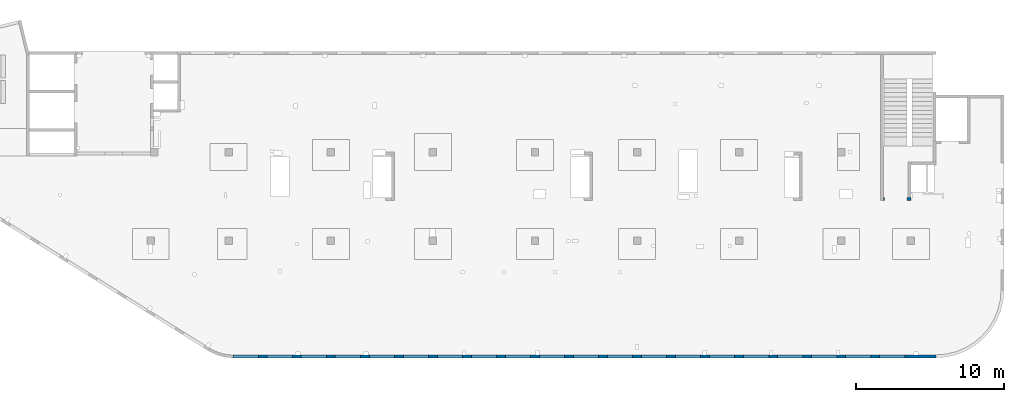
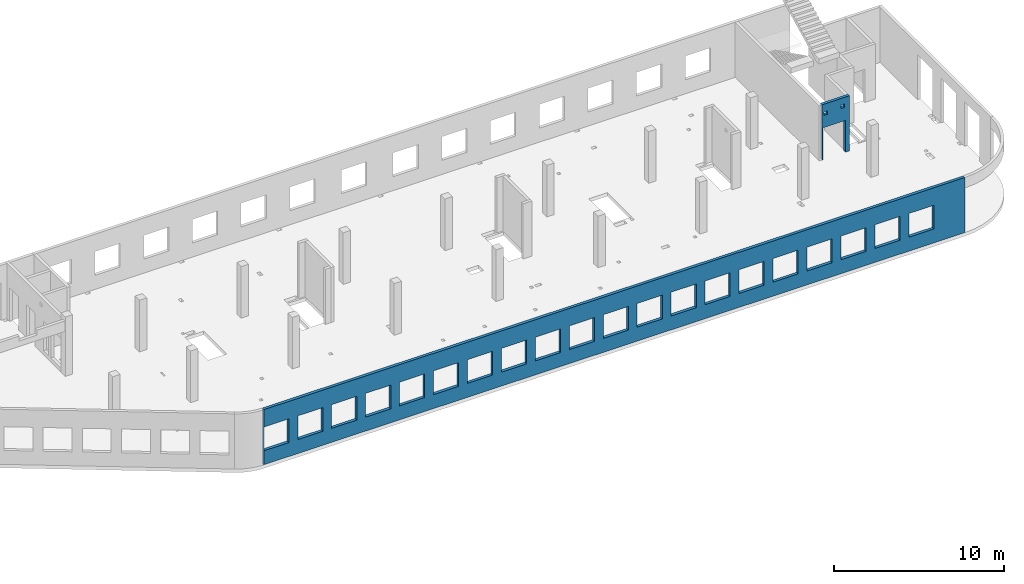
# One storey, part 66 of 67: 2 walls, 23 openings.
"""IFC4 building model written with IfcOpenShell, lengths in millimetres."""

from ifc_helpers import new_model, entity, si_unit, converted_unit, derived_unit, direction, frame, origin, place, context, subcontext, project, spatial, indexed_curve, outline, extrude, polygons, material, type_object, element, save


model = new_model("IFC4")

# Units and contexts
model_context = context("Model", 3, precision=0.01, world=origin(), true_north=direction((6.12303176911189e-17, 1.0)))
plan_context = context("Plan", 3, precision=0.01, world=origin(), true_north=direction((6.12303176911189e-17, 1.0)))
body_context = subcontext(model_context, "Body", "Model", "MODEL_VIEW")
ifc_project = project(units=[si_unit("LENGTHUNIT", "METRE", prefix="MILLI"), si_unit("AREAUNIT", "SQUARE_METRE"), si_unit("VOLUMEUNIT", "CUBIC_METRE"), converted_unit("PLANEANGLEUNIT", "DEGREE", entity("IfcRatioMeasure", 0.0174532925199433), si_unit("PLANEANGLEUNIT", "RADIAN"), dimensions=[0, 0, 0, 0, 0, 0, 0]), si_unit("MASSUNIT", "GRAM", prefix="KILO"), derived_unit("MASSDENSITYUNIT", [(si_unit("MASSUNIT", "GRAM", prefix="KILO"), 1), (si_unit("LENGTHUNIT", "METRE"), -3)]), derived_unit("MOMENTOFINERTIAUNIT", [(si_unit("LENGTHUNIT", "METRE"), 4)]), si_unit("TIMEUNIT", "SECOND"), si_unit("FREQUENCYUNIT", "HERTZ"), si_unit("THERMODYNAMICTEMPERATUREUNIT", "DEGREE_CELSIUS"), derived_unit("THERMALTRANSMITTANCEUNIT", [(si_unit("MASSUNIT", "GRAM", prefix="KILO"), 1), (si_unit("THERMODYNAMICTEMPERATUREUNIT", "KELVIN"), -1), (si_unit("TIMEUNIT", "SECOND"), -3)]), derived_unit("VOLUMETRICFLOWRATEUNIT", [(si_unit("LENGTHUNIT", "METRE"), 3), (si_unit("TIMEUNIT", "SECOND"), -1)]), derived_unit("MASSFLOWRATEUNIT", [(si_unit("MASSUNIT", "GRAM", prefix="KILO"), 1), (si_unit("TIMEUNIT", "SECOND"), -1)]), derived_unit("ROTATIONALFREQUENCYUNIT", [(si_unit("TIMEUNIT", "SECOND"), -1)]), si_unit("ELECTRICCURRENTUNIT", "AMPERE"), si_unit("ELECTRICVOLTAGEUNIT", "VOLT"), si_unit("POWERUNIT", "WATT"), si_unit("FORCEUNIT", "NEWTON", prefix="KILO"), si_unit("ILLUMINANCEUNIT", "LUX"), si_unit("LUMINOUSFLUXUNIT", "LUMEN"), si_unit("LUMINOUSINTENSITYUNIT", "CANDELA"), derived_unit("USERDEFINED", [(si_unit("MASSUNIT", "GRAM", prefix="KILO"), -1), (si_unit("LENGTHUNIT", "METRE"), -2), (si_unit("TIMEUNIT", "SECOND"), 3), (si_unit("LUMINOUSFLUXUNIT", "LUMEN"), 1)]), derived_unit("LINEARVELOCITYUNIT", [(si_unit("LENGTHUNIT", "METRE"), 1), (si_unit("TIMEUNIT", "SECOND"), -1)]), si_unit("PRESSUREUNIT", "PASCAL"), derived_unit("USERDEFINED", [(si_unit("LENGTHUNIT", "METRE"), -2), (si_unit("MASSUNIT", "GRAM", prefix="KILO"), 1), (si_unit("TIMEUNIT", "SECOND"), -2)]), derived_unit("LINEARFORCEUNIT", [(si_unit("MASSUNIT", "GRAM", prefix="KILO"), 1), (si_unit("LENGTHUNIT", "METRE"), 1), (si_unit("TIMEUNIT", "SECOND"), -2), (si_unit("LENGTHUNIT", "METRE"), -1)]), derived_unit("PLANARFORCEUNIT", [(si_unit("MASSUNIT", "GRAM", prefix="KILO"), 1), (si_unit("LENGTHUNIT", "METRE"), 1), (si_unit("TIMEUNIT", "SECOND"), -2), (si_unit("LENGTHUNIT", "METRE"), -2)])], contexts=[model_context, plan_context])

# Site, building, storey
site_placement = place(None, origin())
site = spatial("IfcSite", under=ifc_project, at=site_placement, CompositionType="ELEMENT")
building_placement = place(site_placement, origin())
building = spatial("IfcBuilding", under=site, at=building_placement, CompositionType="ELEMENT")
storey_placement = place(building_placement, frame((0.0, 0.0, 19800.0)))
storey = spatial("IfcBuildingStorey", under=building, at=storey_placement, CompositionType="ELEMENT", Elevation=19800.0)

# Wall, openings
ifc_material = material()
wall_type = type_object("IfcWallType", PredefinedType="STANDARD")
wall_1_placement = place(storey_placement, frame((21465.0002685547, -100.000773644443, -150.0)))
wall_1 = element("IfcWall", 1, at=wall_1_placement, inside=storey, type_object=wall_type, material=ifc_material, PredefinedType="NOTDEFINED", context=body_context, shape_type="Tessellation", body=[
    polygons([(43705.0, -100.0, 2700.0), (45405.0, -100.0, 2700.0), (45405.0, -100.0, 1000.00000000001), (43705.0, -100.0, 1000.00000000001), (41405.0, -100.0, 2700.0), (43105.0, -100.0, 2700.0), (43105.0, -100.0, 1000.00000000001), (41405.0, -100.0, 1000.00000000001), (39105.0, -100.0, 2700.0), (40805.0, -100.0, 2700.0), (40805.0, -100.0, 1000.00000000001), (39105.0, -100.0, 1000.00000000001), (36805.0, -100.0, 2700.0), (38505.0, -100.0, 2700.0), (38505.0, -100.0, 1000.00000000001), (36805.0, -100.0, 1000.00000000001), (34505.0, -100.0, 2700.0), (36205.0, -100.0, 2700.0), (36205.0, -100.0, 1000.00000000001), (34505.0, -100.0, 1000.00000000001), (27605.0, -100.0, 2700.0), (29305.0, -100.0, 2700.0), (29305.0, -100.0, 1000.00000000001), (27605.0, -100.0, 1000.00000000001), (29905.0, -100.0, 2700.0), (31605.0, -100.0, 2700.0), (31605.0, -100.0, 1000.00000000001), (29905.0, -100.0, 1000.00000000001), (32205.0, -100.0, 2700.0), (33905.0, -100.0, 2700.0), (33905.0, -100.0, 1000.00000000001), (32205.0, -100.0, 1000.00000000001), (20705.0, -100.0, 2700.0), (22405.0, -100.0, 2700.0), (22405.0, -100.0, 1000.00000000001), (20705.0, -100.0, 1000.00000000001), (23005.0, -100.0, 2700.0), (24705.0, -100.0, 2700.0), (24705.0, -100.0, 1000.00000000001), (23005.0, -100.0, 1000.00000000001), (25305.0, -100.0, 2700.0), (27005.0, -100.0, 2700.0), (27005.0, -100.0, 1000.00000000001), (25305.0, -100.0, 1000.00000000001), (13805.0, -100.0, 2700.0), (15505.0, -100.0, 2700.0), (15505.0, -100.0, 1000.00000000001), (13805.0, -100.0, 1000.00000000001), (16105.0, -100.0, 2700.0), (17805.0, -100.0, 2700.0), (17805.0, -100.0, 1000.00000000001), (16105.0, -100.0, 1000.00000000001), (18405.0, -100.0, 2700.0), (20105.0, -100.0, 2700.0), (20105.0, -100.0, 1000.00000000001), (18405.0, -100.0, 1000.00000000001), (6904.99999999999, -100.0, 2700.0), (8604.99999999999, -100.0, 2700.0), (8604.99999999999, -100.0, 1000.00000000001), (6904.99999999999, -100.0, 1000.00000000001), (9205.0, -100.0, 2700.0), (10905.0, -100.0, 2700.0), (10905.0, -100.0, 1000.00000000001), (9205.0, -100.0, 1000.00000000001), (11505.0, -100.0, 2700.0), (13205.0, -100.0, 2700.0), (13205.0, -100.0, 1000.00000000001), (11505.0, -100.0, 1000.00000000001), (2305.0, -100.0, 2700.0), (4005.0, -100.0, 2700.0), (4005.0, -100.0, 1000.00000000001), (2305.0, -100.0, 1000.00000000001), (4605.0, -100.0, 2700.0), (6305.00000000001, -100.0, 2700.0), (6305.00000000001, -100.0, 1000.00000000001), (4605.0, -100.0, 1000.00000000001), (5.00000000000384, -100.0, 2700.0), (1705.0, -100.0, 2700.0), (1705.0, -100.0, 1000.00000000001), (5.00000000000384, -100.0, 1000.00000000001), (6.46235172450444e-13, -100.0, 0.0), (47505.0, -100.0, 0.0), (47505.0, -100.0, 3950.0), (4.65284088467406, -100.0, 3950.0), (4.97770368964401e-12, -100.0, 3950.0), (45405.0, 100.000000000321, 2700.0), (43705.0, 100.000000000321, 2700.0), (43705.0, 100.000000000321, 1000.00000000001), (45405.0, 100.000000000321, 1000.00000000001), (43105.0, 100.000000000321, 2700.0), (41405.0, 100.000000000321, 2700.0), (41405.0, 100.000000000321, 1000.00000000001), (43105.0, 100.000000000321, 1000.00000000001), (40805.0, 100.000000000321, 2700.0), (39105.0, 100.000000000321, 2700.0), (39105.0, 100.000000000321, 1000.00000000001), (40805.0, 100.000000000321, 1000.00000000001), (38505.0, 100.000000000321, 2700.0), (36805.0, 100.000000000321, 2700.0), (36805.0, 100.000000000321, 1000.00000000001), (38505.0, 100.000000000321, 1000.00000000001), (36205.0, 100.000000000321, 2700.0), (34505.0, 100.000000000321, 2700.0), (34505.0, 100.000000000321, 1000.00000000001), (36205.0, 100.000000000321, 1000.00000000001), (29305.0, 100.000000000321, 2700.0), (27605.0, 100.000000000321, 2700.0), (27605.0, 100.000000000321, 1000.00000000001), (29305.0, 100.000000000321, 1000.00000000001), (31605.0, 100.000000000321, 2700.0), (29905.0, 100.000000000321, 2700.0), (29905.0, 100.000000000321, 1000.00000000001), (31605.0, 100.000000000321, 1000.00000000001), (33905.0, 100.000000000321, 2700.0), (32205.0, 100.000000000321, 2700.0), (32205.0, 100.000000000321, 1000.00000000001), (33905.0, 100.000000000321, 1000.00000000001), (22405.0, 100.000000000321, 2700.0), (20705.0, 100.000000000321, 2700.0), (20705.0, 100.000000000321, 1000.00000000001), (22405.0, 100.000000000321, 1000.00000000001), (24705.0, 100.000000000321, 2700.0), (23005.0, 100.000000000321, 2700.0), (23005.0, 100.000000000321, 1000.00000000001), (24705.0, 100.000000000321, 1000.00000000001), (27005.0, 100.000000000321, 2700.0), (25305.0, 100.000000000321, 2700.0), (25305.0, 100.000000000321, 1000.00000000001), (27005.0, 100.000000000321, 1000.00000000001), (15505.0, 100.000000000321, 2700.0), (13805.0, 100.000000000321, 2700.0), (13805.0, 100.000000000321, 1000.00000000001), (15505.0, 100.000000000321, 1000.00000000001), (17805.0, 100.000000000321, 2700.0), (16105.0, 100.000000000321, 2700.0), (16105.0, 100.000000000321, 1000.00000000001), (17805.0, 100.000000000321, 1000.00000000001), (20105.0, 100.000000000321, 2700.0), (18405.0, 100.000000000321, 2700.0), (18405.0, 100.000000000321, 1000.00000000001), (20105.0, 100.000000000321, 1000.00000000001), (8604.99999999998, 100.000000000321, 2700.0), (6904.99999999999, 100.000000000321, 2700.0), (6904.99999999999, 100.000000000321, 1000.00000000001), (8604.99999999998, 100.000000000321, 1000.00000000001), (10905.0, 100.000000000321, 2700.0), (9204.99999999999, 100.000000000321, 2700.0), (9204.99999999999, 100.000000000321, 1000.00000000001), (10905.0, 100.000000000321, 1000.00000000001), (13205.0, 100.000000000321, 2700.0), (11505.0, 100.000000000321, 2700.0), (11505.0, 100.000000000321, 1000.00000000001), (13205.0, 100.000000000321, 1000.00000000001), (4005.0, 100.000000000321, 2700.0), (2305.0, 100.000000000321, 2700.0), (2305.0, 100.000000000321, 1000.00000000001), (4005.0, 100.000000000321, 1000.00000000001), (6305.0, 100.000000000321, 2700.0), (4605.0, 100.000000000321, 2700.0), (4605.0, 100.000000000321, 1000.00000000001), (6305.0, 100.000000000321, 1000.00000000001), (1705.0, 100.000000000321, 2700.0), (5.00000000000319, 100.000000000321, 2700.0), (5.00000000000319, 100.000000000321, 1000.00000000002), (1705.0, 100.000000000321, 1000.00000000002), (47505.0, 100.0, 0.0), (46305.0, 100.0, 0.0), (46005.0, 100.0, 0.0), (40985.0, 100.0, 0.0), (40785.0, 100.0, 0.0), (36475.0, 100.0, 0.0), (36275.0, 100.0, 0.0), (31965.0, 100.0, 0.0), (31765.0, 100.0, 0.0), (20675.0, 100.0, 0.0), (20475.0, 100.0, 0.0), (15725.0, 100.0, 0.0), (15525.0, 100.0, 0.0), (9114.99999999999, 100.0, 0.0), (8814.99999999999, 100.0, 0.0), (4534.99999999999, 100.0, 0.0), (4234.99999999999, 100.0, 0.0), (2.49977157936766e-18, 100.0, 0.0), (4.33147101696515e-12, 100.0, 3950.0), (4234.99999999999, 100.0, 3950.0), (4535.0, 100.0, 3950.0), (8930.0, 100.0, 3950.0), (9130.0, 100.0, 3950.0), (13355.0, 100.0, 3950.0), (13655.0, 100.0, 3950.0), (18105.0, 100.0, 3950.0), (18405.0, 100.0, 3950.0), (24805.0, 100.0, 3950.0), (25105.0, 100.0, 3950.0), (31805.0, 100.0, 3950.0), (32105.0, 100.0, 3950.0), (36405.0, 100.0, 3950.0), (36705.0, 100.0, 3950.0), (41005.0, 100.0, 3950.0), (41305.0, 100.0, 3950.0), (46005.0, 100.0, 3950.0), (46305.0, 100.0, 3950.0), (47505.0, 100.0, 3950.0)], [[[81, 82, 83, 84, 85], [1, 2, 3, 4], [5, 6, 7, 8], [9, 10, 11, 12], [13, 14, 15, 16], [17, 18, 19, 20], [21, 22, 23, 24], [25, 26, 27, 28], [29, 30, 31, 32], [33, 34, 35, 36], [37, 38, 39, 40], [41, 42, 43, 44], [45, 46, 47, 48], [49, 50, 51, 52], [53, 54, 55, 56], [57, 58, 59, 60], [61, 62, 63, 64], [65, 66, 67, 68], [69, 70, 71, 72], [73, 74, 75, 76], [77, 78, 79, 80]], [[166, 167, 168, 169, 170, 171, 172, 173, 174, 175, 176, 177, 178, 179, 180, 181, 182, 183, 184, 185, 186, 187, 188, 189, 190, 191, 192, 193, 194, 195, 196, 197, 198, 199, 200, 201, 202, 203], [86, 87, 88, 89], [90, 91, 92, 93], [94, 95, 96, 97], [98, 99, 100, 101], [102, 103, 104, 105], [106, 107, 108, 109], [110, 111, 112, 113], [114, 115, 116, 117], [118, 119, 120, 121], [122, 123, 124, 125], [126, 127, 128, 129], [130, 131, 132, 133], [134, 135, 136, 137], [138, 139, 140, 141], [142, 143, 144, 145], [146, 147, 148, 149], [150, 151, 152, 153], [154, 155, 156, 157], [158, 159, 160, 161], [162, 163, 164, 165]], [[82, 81, 183, 182, 181, 180, 179, 178, 177, 176, 175, 174, 173, 172, 171, 170, 169, 168, 167, 166]], [[83, 82, 166, 203]], [[85, 84, 83, 203, 202, 201, 200, 199, 198, 197, 196, 195, 194, 193, 192, 191, 190, 189, 188, 187, 186, 185, 184]], [[81, 85, 184, 183]], [[87, 86, 2, 1]], [[87, 1, 4, 88]], [[88, 4, 3, 89]], [[2, 86, 89, 3]], [[91, 90, 6, 5]], [[91, 5, 8, 92]], [[92, 8, 7, 93]], [[6, 90, 93, 7]], [[95, 94, 10, 9]], [[95, 9, 12, 96]], [[96, 12, 11, 97]], [[10, 94, 97, 11]], [[99, 98, 14, 13]], [[99, 13, 16, 100]], [[100, 16, 15, 101]], [[14, 98, 101, 15]], [[103, 102, 18, 17]], [[103, 17, 20, 104]], [[104, 20, 19, 105]], [[18, 102, 105, 19]], [[107, 106, 22, 21]], [[107, 21, 24, 108]], [[108, 24, 23, 109]], [[22, 106, 109, 23]], [[111, 110, 26, 25]], [[111, 25, 28, 112]], [[112, 28, 27, 113]], [[26, 110, 113, 27]], [[115, 114, 30, 29]], [[115, 29, 32, 116]], [[116, 32, 31, 117]], [[30, 114, 117, 31]], [[119, 118, 34, 33]], [[119, 33, 36, 120]], [[120, 36, 35, 121]], [[34, 118, 121, 35]], [[123, 122, 38, 37]], [[123, 37, 40, 124]], [[124, 40, 39, 125]], [[38, 122, 125, 39]], [[127, 126, 42, 41]], [[127, 41, 44, 128]], [[128, 44, 43, 129]], [[42, 126, 129, 43]], [[131, 130, 46, 45]], [[131, 45, 48, 132]], [[132, 48, 47, 133]], [[46, 130, 133, 47]], [[135, 134, 50, 49]], [[135, 49, 52, 136]], [[136, 52, 51, 137]], [[50, 134, 137, 51]], [[139, 138, 54, 53]], [[139, 53, 56, 140]], [[140, 56, 55, 141]], [[54, 138, 141, 55]], [[143, 142, 58, 57]], [[143, 57, 60, 144]], [[144, 60, 59, 145]], [[58, 142, 145, 59]], [[147, 146, 62, 61]], [[147, 61, 64, 148]], [[148, 64, 63, 149]], [[62, 146, 149, 63]], [[151, 150, 66, 65]], [[151, 65, 68, 152]], [[152, 68, 67, 153]], [[66, 150, 153, 67]], [[155, 154, 70, 69]], [[155, 69, 72, 156]], [[156, 72, 71, 157]], [[70, 154, 157, 71]], [[159, 158, 74, 73]], [[159, 73, 76, 160]], [[160, 76, 75, 161]], [[74, 158, 161, 75]], [[77, 163, 162, 78]], [[163, 77, 80, 164]], [[164, 80, 79, 165]], [[78, 162, 165, 79]]], closed=True),
])
opening_1_placement = place(wall_1_placement, frame((-21465.0002685547, 100.000773644443, 150.0)))
element("IfcOpeningElement", 2, at=opening_1_placement, cuts=wall_1, PredefinedType="OPENING", context=body_context, shape_type="SweptSolid", body=[
    extrude(outline(indexed_curve([(-849.999999999993, -850.000000000002), (849.999999999993, -850.000000000002), (849.999999999993, 849.999999999997), (-849.999999999993, 849.999999999997), (-849.999999999993, -850.000000000002)], self_intersect=False)), frame((22320.0002685547, -200.000773644445, 1700.0), z_axis=(0.0, 1.0, 0.0), x_axis=(0.0, 0.0, -1.0)), (0.0, 0.0, 1.0), 200.000000000962),
])
opening_2_placement = place(wall_1_placement, frame((-21465.0002685547, 100.000773644443, 150.0)))
element("IfcOpeningElement", 3, at=opening_2_placement, cuts=wall_1, PredefinedType="OPENING", context=body_context, shape_type="SweptSolid", body=[
    extrude(outline(indexed_curve([(-849.999999999993, -850.000000000006), (849.999999999993, -850.000000000006), (849.999999999993, 849.999999999997), (-849.999999999993, 849.999999999997), (-849.999999999993, -850.000000000006)], self_intersect=False)), frame((66020.0002685547, -200.000773644587, 1700.0), z_axis=(0.0, 1.0, 0.0), x_axis=(0.0, 0.0, -1.0)), (0.0, 0.0, 1.0), 200.000000000962),
])
opening_3_placement = place(wall_1_placement, frame((-21465.0002685547, 100.000773644443, 150.0)))
element("IfcOpeningElement", 4, at=opening_3_placement, cuts=wall_1, PredefinedType="OPENING", context=body_context, shape_type="SweptSolid", body=[
    extrude(outline(indexed_curve([(-849.999999999993, -850.000000000006), (849.999999999993, -850.000000000006), (849.999999999993, 849.999999999997), (-849.999999999993, 849.999999999997), (-849.999999999993, -850.000000000006)], self_intersect=False)), frame((63720.0002685547, -200.000773644579, 1700.0), z_axis=(0.0, 1.0, 0.0), x_axis=(0.0, 0.0, -1.0)), (0.0, 0.0, 1.0), 200.000000000962),
])
opening_4_placement = place(wall_1_placement, frame((-21465.0002685547, 100.000773644443, 150.0)))
element("IfcOpeningElement", 5, at=opening_4_placement, cuts=wall_1, PredefinedType="OPENING", context=body_context, shape_type="SweptSolid", body=[
    extrude(outline(indexed_curve([(-849.999999999993, -850.000000000006), (849.999999999993, -850.000000000006), (849.999999999993, 849.999999999997), (-849.999999999993, 849.999999999997), (-849.999999999993, -850.000000000006)], self_intersect=False)), frame((61420.0002685547, -200.000773644572, 1700.0), z_axis=(0.0, 1.0, 0.0), x_axis=(0.0, 0.0, -1.0)), (0.0, 0.0, 1.0), 200.000000000962),
])
opening_5_placement = place(wall_1_placement, frame((-21465.0002685547, 100.000773644443, 150.0)))
element("IfcOpeningElement", 6, at=opening_5_placement, cuts=wall_1, PredefinedType="OPENING", context=body_context, shape_type="SweptSolid", body=[
    extrude(outline(indexed_curve([(-849.999999999993, -849.999999999997), (849.999999999993, -849.999999999997), (849.999999999993, 850.000000000006), (-849.999999999993, 850.000000000006), (-849.999999999993, -849.999999999997)], self_intersect=False)), frame((59120.0002685547, -200.000773644564, 1700.0), z_axis=(0.0, 1.0, 0.0), x_axis=(0.0, 0.0, -1.0)), (0.0, 0.0, 1.0), 200.000000000962),
])
opening_6_placement = place(wall_1_placement, frame((-21465.0002685547, 100.000773644443, 150.0)))
element("IfcOpeningElement", 7, at=opening_6_placement, cuts=wall_1, PredefinedType="OPENING", context=body_context, shape_type="SweptSolid", body=[
    extrude(outline(indexed_curve([(-849.999999999993, -850.000000000006), (849.999999999993, -850.000000000006), (849.999999999993, 849.999999999997), (-849.999999999993, 849.999999999997), (-849.999999999993, -850.000000000006)], self_intersect=False)), frame((56820.0002685547, -200.000773644557, 1700.0), z_axis=(0.0, 1.0, 0.0), x_axis=(0.0, 0.0, -1.0)), (0.0, 0.0, 1.0), 200.000000000962),
])
opening_7_placement = place(wall_1_placement, frame((-21465.0002685547, 100.000773644443, 150.0)))
element("IfcOpeningElement", 8, at=opening_7_placement, cuts=wall_1, PredefinedType="OPENING", context=body_context, shape_type="SweptSolid", body=[
    extrude(outline(indexed_curve([(-849.999999999993, -849.999999999997), (849.999999999993, -849.999999999997), (849.999999999993, 850.000000000006), (-849.999999999993, 850.000000000006), (-849.999999999993, -849.999999999997)], self_intersect=False)), frame((54520.0002685547, -200.000773644549, 1700.0), z_axis=(0.0, 1.0, 0.0), x_axis=(0.0, 0.0, -1.0)), (0.0, 0.0, 1.0), 200.000000000962),
])
opening_8_placement = place(wall_1_placement, frame((-21465.0002685547, 100.000773644443, 150.0)))
element("IfcOpeningElement", 9, at=opening_8_placement, cuts=wall_1, PredefinedType="OPENING", context=body_context, shape_type="SweptSolid", body=[
    extrude(outline(indexed_curve([(-849.999999999993, -850.000000000006), (849.999999999993, -850.000000000006), (849.999999999993, 849.999999999997), (-849.999999999993, 849.999999999997), (-849.999999999993, -850.000000000006)], self_intersect=False)), frame((52220.0002685547, -200.000773644542, 1700.0), z_axis=(0.0, 1.0, 0.0), x_axis=(0.0, 0.0, -1.0)), (0.0, 0.0, 1.0), 200.000000000962),
])
opening_9_placement = place(wall_1_placement, frame((-21465.0002685547, 100.000773644443, 150.0)))
element("IfcOpeningElement", 10, at=opening_9_placement, cuts=wall_1, PredefinedType="OPENING", context=body_context, shape_type="SweptSolid", body=[
    extrude(outline(indexed_curve([(-849.999999999993, -850.000000000006), (849.999999999993, -850.000000000006), (849.999999999993, 849.999999999997), (-849.999999999993, 849.999999999997), (-849.999999999993, -850.000000000006)], self_intersect=False)), frame((49920.0002685547, -200.000773644535, 1700.0), z_axis=(0.0, 1.0, 0.0), x_axis=(0.0, 0.0, -1.0)), (0.0, 0.0, 1.0), 200.000000000962),
])
opening_10_placement = place(wall_1_placement, frame((-21465.0002685547, 100.000773644443, 150.0)))
element("IfcOpeningElement", 11, at=opening_10_placement, cuts=wall_1, PredefinedType="OPENING", context=body_context, shape_type="SweptSolid", body=[
    extrude(outline(indexed_curve([(-849.999999999993, -850.000000000006), (849.999999999993, -850.000000000006), (849.999999999993, 849.999999999997), (-849.999999999993, 849.999999999997), (-849.999999999993, -850.000000000006)], self_intersect=False)), frame((47620.0002685547, -200.000773644527, 1700.0), z_axis=(0.0, 1.0, 0.0), x_axis=(0.0, 0.0, -1.0)), (0.0, 0.0, 1.0), 200.000000000962),
])
opening_11_placement = place(wall_1_placement, frame((-21465.0002685547, 100.000773644443, 150.0)))
element("IfcOpeningElement", 12, at=opening_11_placement, cuts=wall_1, PredefinedType="OPENING", context=body_context, shape_type="SweptSolid", body=[
    extrude(outline(indexed_curve([(-849.999999999993, -850.000000000006), (849.999999999993, -850.000000000006), (849.999999999993, 849.999999999997), (-849.999999999993, 849.999999999997), (-849.999999999993, -850.000000000006)], self_intersect=False)), frame((45320.0002685547, -200.00077364452, 1700.0), z_axis=(0.0, 1.0, 0.0), x_axis=(0.0, 0.0, -1.0)), (0.0, 0.0, 1.0), 200.000000000962),
])
opening_12_placement = place(wall_1_placement, frame((-21465.0002685547, 100.000773644443, 150.0)))
element("IfcOpeningElement", 13, at=opening_12_placement, cuts=wall_1, PredefinedType="OPENING", context=body_context, shape_type="SweptSolid", body=[
    extrude(outline(indexed_curve([(-849.999999999993, -849.999999999997), (849.999999999993, -849.999999999997), (849.999999999993, 850.000000000006), (-849.999999999993, 850.000000000006), (-849.999999999993, -849.999999999997)], self_intersect=False)), frame((43020.0002685547, -200.000773644512, 1700.0), z_axis=(0.0, 1.0, 0.0), x_axis=(0.0, 0.0, -1.0)), (0.0, 0.0, 1.0), 200.000000000962),
])
opening_13_placement = place(wall_1_placement, frame((-21465.0002685547, 100.000773644443, 150.0)))
element("IfcOpeningElement", 14, at=opening_13_placement, cuts=wall_1, PredefinedType="OPENING", context=body_context, shape_type="SweptSolid", body=[
    extrude(outline(indexed_curve([(-849.999999999993, -850.000000000006), (849.999999999993, -850.000000000006), (849.999999999993, 849.999999999997), (-849.999999999993, 849.999999999997), (-849.999999999993, -850.000000000006)], self_intersect=False)), frame((40720.0002685547, -200.000773644505, 1700.0), z_axis=(0.0, 1.0, 0.0), x_axis=(0.0, 0.0, -1.0)), (0.0, 0.0, 1.0), 200.000000000962),
])
opening_14_placement = place(wall_1_placement, frame((-21465.0002685547, 100.000773644443, 150.0)))
element("IfcOpeningElement", 15, at=opening_14_placement, cuts=wall_1, PredefinedType="OPENING", context=body_context, shape_type="SweptSolid", body=[
    extrude(outline(indexed_curve([(-849.999999999993, -850.000000000002), (849.999999999993, -850.000000000002), (849.999999999993, 850.000000000002), (-849.999999999993, 850.000000000002), (-849.999999999993, -850.000000000002)], self_intersect=False)), frame((38420.0002685547, -200.000773644497, 1700.0), z_axis=(0.0, 1.0, 0.0), x_axis=(0.0, 0.0, -1.0)), (0.0, 0.0, 1.0), 200.000000000962),
])
opening_15_placement = place(wall_1_placement, frame((-21465.0002685547, 100.000773644443, 150.0)))
element("IfcOpeningElement", 16, at=opening_15_placement, cuts=wall_1, PredefinedType="OPENING", context=body_context, shape_type="SweptSolid", body=[
    extrude(outline(indexed_curve([(-849.999999999993, -849.999999999997), (849.999999999993, -849.999999999997), (849.999999999993, 850.000000000002), (-849.999999999993, 850.000000000002), (-849.999999999993, -849.999999999997)], self_intersect=False)), frame((36120.0002685547, -200.00077364449, 1700.0), z_axis=(0.0, 1.0, 0.0), x_axis=(0.0, 0.0, -1.0)), (0.0, 0.0, 1.0), 200.000000000962),
])
opening_16_placement = place(wall_1_placement, frame((-21465.0002685547, 100.000773644443, 150.0)))
element("IfcOpeningElement", 17, at=opening_16_placement, cuts=wall_1, PredefinedType="OPENING", context=body_context, shape_type="SweptSolid", body=[
    extrude(outline(indexed_curve([(-849.999999999993, -850.000000000002), (849.999999999993, -850.000000000002), (849.999999999993, 849.999999999997), (-849.999999999993, 849.999999999997), (-849.999999999993, -850.000000000002)], self_intersect=False)), frame((33820.0002685547, -200.000773644483, 1700.0), z_axis=(0.0, 1.0, 0.0), x_axis=(0.0, 0.0, -1.0)), (0.0, 0.0, 1.0), 200.000000000962),
])
opening_17_placement = place(wall_1_placement, frame((-21465.0002685547, 100.000773644443, 150.0)))
element("IfcOpeningElement", 18, at=opening_17_placement, cuts=wall_1, PredefinedType="OPENING", context=body_context, shape_type="SweptSolid", body=[
    extrude(outline(indexed_curve([(-849.999999999993, -850.000000000002), (849.999999999993, -850.000000000002), (849.999999999993, 849.999999999997), (-849.999999999993, 849.999999999997), (-849.999999999993, -850.000000000002)], self_intersect=False)), frame((31520.0002685547, -200.000773644475, 1700.0), z_axis=(0.0, 1.0, 0.0), x_axis=(0.0, 0.0, -1.0)), (0.0, 0.0, 1.0), 200.000000000962),
])
opening_18_placement = place(wall_1_placement, frame((-21465.0002685547, 100.000773644443, 150.0)))
element("IfcOpeningElement", 19, at=opening_18_placement, cuts=wall_1, PredefinedType="OPENING", context=body_context, shape_type="SweptSolid", body=[
    extrude(outline(indexed_curve([(-849.999999999993, -850.000000000002), (849.999999999993, -850.000000000002), (849.999999999993, 849.999999999997), (-849.999999999993, 849.999999999997), (-849.999999999993, -850.000000000002)], self_intersect=False)), frame((29220.0002685547, -200.000773644468, 1700.0), z_axis=(0.0, 1.0, 0.0), x_axis=(0.0, 0.0, -1.0)), (0.0, 0.0, 1.0), 200.000000000962),
])
opening_19_placement = place(wall_1_placement, frame((-21465.0002685547, 100.000773644443, 150.0)))
element("IfcOpeningElement", 20, at=opening_19_placement, cuts=wall_1, PredefinedType="OPENING", context=body_context, shape_type="SweptSolid", body=[
    extrude(outline(indexed_curve([(-849.999999999993, -850.000000000002), (849.999999999993, -850.000000000002), (849.999999999993, 849.999999999997), (-849.999999999993, 849.999999999997), (-849.999999999993, -850.000000000002)], self_intersect=False)), frame((26920.0002685547, -200.00077364446, 1700.0), z_axis=(0.0, 1.0, 0.0), x_axis=(0.0, 0.0, -1.0)), (0.0, 0.0, 1.0), 200.000000000962),
])
opening_20_placement = place(wall_1_placement, frame((-21465.0002685547, 100.000773644443, 150.0)))
element("IfcOpeningElement", 21, at=opening_20_placement, cuts=wall_1, PredefinedType="OPENING", context=body_context, shape_type="SweptSolid", body=[
    extrude(outline(indexed_curve([(-849.999999999993, -850.000000000002), (849.999999999993, -850.000000000002), (849.999999999993, 849.999999999997), (-849.999999999993, 849.999999999997), (-849.999999999993, -850.000000000002)], self_intersect=False)), frame((24620.0002685547, -200.000773644453, 1700.0), z_axis=(0.0, 1.0, 0.0), x_axis=(0.0, 0.0, -1.0)), (0.0, 0.0, 1.0), 200.000000000962),
])

wall_2_placement = place(storey_placement, frame((65430.0002685547, 10524.9992263555, -150.0)))
wall_2 = element("IfcWall", 22, at=wall_2_placement, inside=storey, type_object=wall_type, material=ifc_material, PredefinedType="NOTDEFINED", context=body_context, shape_type="Tessellation", body=[
    polygons([(1850.0, -100.000000000001, 3950.0), (0.0, -100.000000000001, 3950.0), (0.0, -100.000000000001, 0.0), (75.0000000000003, -100.000000000001, 0.0), (75.0000000000003, -100.000000000001, 2279.99999999804), (1575.00000000001, -100.000000000001, 2279.99999999804), (1575.00000000001, -100.000000000001, 0.0), (1850.0, -100.000000000001, 0.0), (125.000000000006, -100.000000000001, 3400.0), (374.999999999993, -100.000000000001, 3400.0), (374.999999999993, -100.000000000001, 3150.00000000001), (125.000000000006, -100.000000000001, 3150.00000000001), (1274.99999999999, -100.000000000001, 3490.0), (1524.99999999998, -100.000000000001, 3490.0), (1524.99999999998, -100.000000000001, 3240.00000000001), (1274.99999999999, -100.000000000001, 3240.00000000001), (0.0, 99.9999999999989, 3950.0), (1650.0, 99.9999999999989, 3950.0), (1850.0, 99.9999999999989, 3950.0), (1850.0, 99.9999999999989, 0.0), (1650.0, 99.9999999999989, 0.0), (1575.00000000001, 99.9999999999989, 0.0), (1575.00000000001, 99.9999999999989, 2279.99999999804), (75.0000000000003, 99.9999999999989, 2279.99999999804), (75.0000000000003, 99.9999999999989, 0.0), (0.0, 99.9999999999989, 0.0), (374.999999999993, 100.000000000322, 3400.0), (125.000000000006, 100.000000000322, 3400.0), (125.000000000006, 100.000000000322, 3150.00000000001), (374.999999999993, 100.000000000322, 3150.00000000001), (1524.99999999998, 100.000000000322, 3490.0), (1274.99999999999, 100.000000000322, 3490.0), (1274.99999999999, 100.000000000322, 3240.00000000001), (1524.99999999998, 100.000000000322, 3240.00000000001), (1850.0, 39.9999999999454, 3950.0)], [[[1, 2, 3, 4, 5, 6, 7, 8], [9, 10, 11, 12], [13, 14, 15, 16]], [[17, 18, 19, 20, 21, 22, 23, 24, 25, 26], [27, 28, 29, 30], [31, 32, 33, 34]], [[3, 26, 25, 4]], [[2, 1, 35, 19, 18, 17]], [[3, 2, 17, 26]], [[1, 8, 20, 19, 35]], [[23, 6, 5, 24]], [[24, 5, 4, 25]], [[6, 23, 22, 7]], [[9, 28, 27, 10]], [[28, 9, 12, 29]], [[29, 12, 11, 30]], [[10, 27, 30, 11]], [[32, 31, 14, 13]], [[32, 13, 16, 33]], [[33, 16, 15, 34]], [[14, 31, 34, 15]], [[20, 8, 7, 22, 21]]], closed=True),
])
opening_21_placement = place(wall_2_placement, frame((-65430.0002685547, -10524.9992263555, 150.0)))
element("IfcOpeningElement", 23, at=opening_21_placement, cuts=wall_2, PredefinedType="OPENING", context=body_context, shape_type="SweptSolid", body=[
    extrude(outline(indexed_curve([(-1139.99999999902, -750.000000000003), (1139.99999999902, -750.000000000003), (1139.99999999902, 749.999999999994), (-1139.99999999902, 749.999999999994), (-1139.99999999902, -750.000000000003)], self_intersect=False)), frame((66255.0002685547, 10324.9992263555, 990.0), z_axis=(0.0, 1.0, 0.0), x_axis=(0.0, 0.0, -1.0)), (0.0, 0.0, 1.0), 400.000000001943),
])
opening_22_placement = place(wall_2_placement, frame((-65430.0002685547, -10524.9992263555, 150.0)))
element("IfcOpeningElement", 24, at=opening_22_placement, cuts=wall_2, PredefinedType="OPENING", context=body_context, shape_type="SweptSolid", body=[
    extrude(outline(indexed_curve([(-124.999999999993, -124.999999999998), (124.999999999993, -124.999999999998), (124.999999999993, 125.000000000006), (-124.999999999993, 125.000000000006), (-124.999999999993, -124.999999999998)], self_intersect=False)), frame((65680.0002685547, 10424.9992263555, 3125.0), z_axis=(0.0, 1.0, 0.0), x_axis=(0.0, 0.0, -1.0)), (0.0, 0.0, 1.0), 200.000000000962),
])
opening_23_placement = place(wall_2_placement, frame((-65430.0002685547, -10524.9992263555, 150.0)))
element("IfcOpeningElement", 25, at=opening_23_placement, cuts=wall_2, PredefinedType="OPENING", context=body_context, shape_type="SweptSolid", body=[
    extrude(outline(indexed_curve([(-124.999999999993, -124.999999999998), (124.999999999993, -124.999999999998), (124.999999999993, 125.000000000006), (-124.999999999993, 125.000000000006), (-124.999999999993, -124.999999999998)], self_intersect=False)), frame((66830.0002685547, 10424.9992263555, 3215.0), z_axis=(0.0, 1.0, 0.0), x_axis=(0.0, 0.0, -1.0)), (0.0, 0.0, 1.0), 200.000000000962),
])

save(model, "model.ifc")
